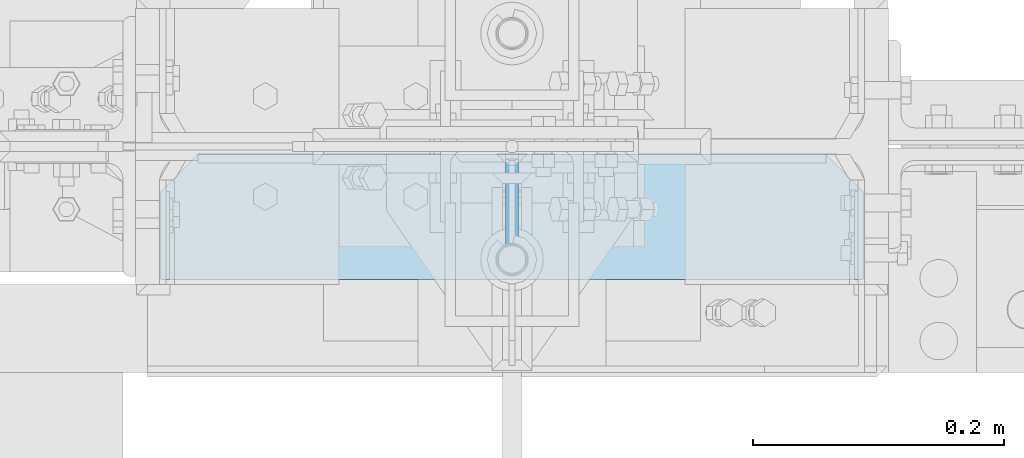
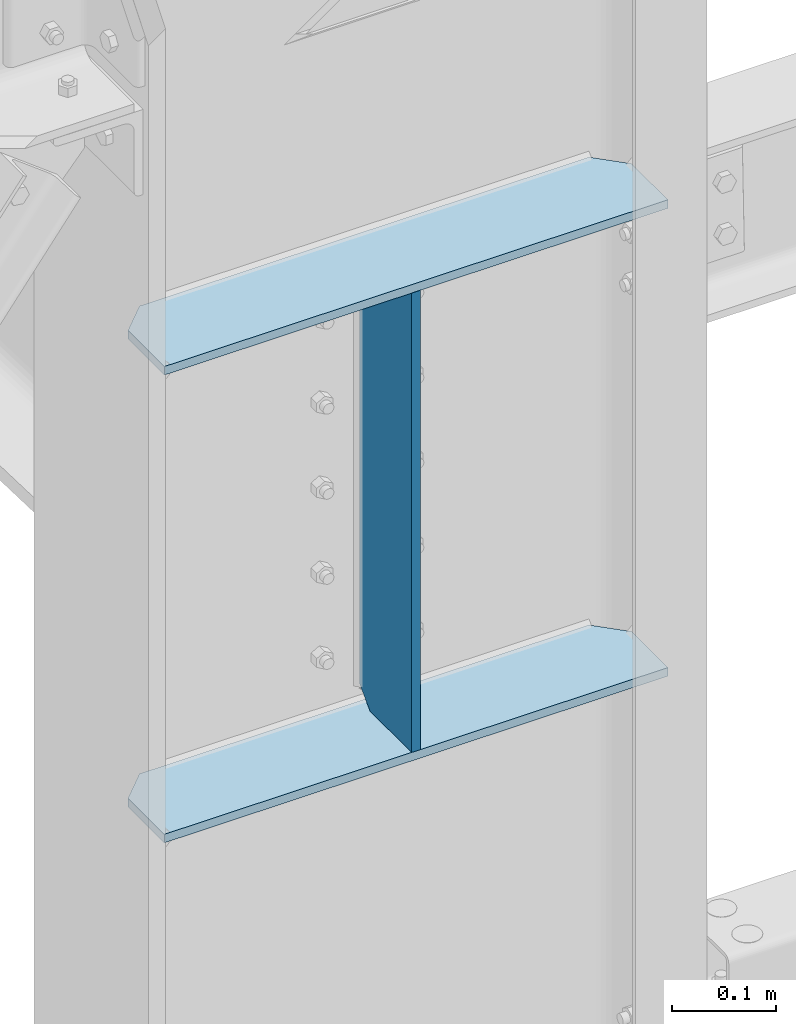
# One storey, part 130 of 496: 3 plates, 1 element without a shape of its own.
"""IFC2X3 building model written with IfcOpenShell, lengths in millimetres."""

from ifc_helpers import new_model, si_unit, frame, origin_with_axes, place, context, subcontext, project, spatial, polyline, outline, extrude, material, type_object, element, aggregate, save


model = new_model("IFC2X3")

# Units and contexts
model_context = context("Model", 3, precision=1e-05, world=origin_with_axes())
body_context = subcontext(model_context, "Body", "Model", "MODEL_VIEW")
ifc_project = project(units=[si_unit("LENGTHUNIT", "METRE", prefix="MILLI"), si_unit("AREAUNIT", "SQUARE_METRE"), si_unit("VOLUMEUNIT", "CUBIC_METRE"), si_unit("MASSUNIT", "GRAM", prefix="KILO"), si_unit("TIMEUNIT", "SECOND"), si_unit("PLANEANGLEUNIT", "RADIAN"), si_unit("SOLIDANGLEUNIT", "STERADIAN"), si_unit("THERMODYNAMICTEMPERATUREUNIT", "DEGREE_CELSIUS"), si_unit("LUMINOUSINTENSITYUNIT", "LUMEN")], contexts=[model_context])

# Site, building, storey
site_placement = place(None, origin_with_axes())
site = spatial("IfcSite", under=ifc_project, at=site_placement, CompositionType="ELEMENT")
building_placement = place(site_placement, origin_with_axes())
building = spatial("IfcBuilding", under=site, at=building_placement, Name="Undefined", CompositionType="ELEMENT")
storey_placement = place(building_placement, origin_with_axes())
storey = spatial("IfcBuildingStorey", under=building, at=storey_placement, Name="Undefined", CompositionType="ELEMENT", Elevation=0.0)

# Assembly, plates
assembly_placement = place(storey_placement, origin_with_axes())
assembly = element("IfcElementAssembly", 1, at=assembly_placement, inside=storey, Name="POTEAU", AssemblyPlace="NOTDEFINED", PredefinedType="NOTDEFINED")
ifc_material = material(Name="Undefined/S235-E24")
plate_type = type_object("IfcPlateType", PredefinedType="NOTDEFINED")
plate_1_placement = place(assembly_placement, frame((28879.9998414389, -106.0, 8044.34004841327), z_axis=(-1.0, 0.0, 0.0), x_axis=(0.0, 1.0, 0.0)))
plate_1 = element("IfcPlate", 2, at=plate_1_placement, type_object=plate_type, material=ifc_material, context=body_context, shape_type="SweptSolid", body=[
    extrude(outline(polyline([(0.0, 0.0), (80.00000000008, 8.00355337560177e-11), (100.0, 20.0), (100.0, 520.000000000172), (80.0, 540.000000000172), (-5.6843418860808e-14, 540.000000000172), (0.0, 0.0)])), frame((0.0, 0.0, -5.0), z_axis=(0.0, 0.0, 1.0), x_axis=(1.0, 0.0, 0.0)), (0.0, 0.0, 1.0), 10.0),
])
plate_2_placement = place(assembly_placement, frame((29159.9996632239, -106.0, 7499.33995685333), z_axis=(0.0, 0.0, 1.0), x_axis=(0.0, 1.0, 0.0)))
plate_2 = element("IfcPlate", 3, at=plate_2_placement, type_object=plate_type, material=ifc_material, context=body_context, shape_type="SweptSolid", body=[
    extrude(outline(polyline([(0.0, 0.0), (70.0, 0.0), (100.0, 30.0), (100.0, 530.000000000175), (70.0, 560.000000000175), (0.0, 560.000000000175), (0.0, 0.0)])), frame((0.0, 0.0, -5.0), z_axis=(0.0, 0.0, 1.0), x_axis=(1.0, 0.0, 0.0)), (0.0, 0.0, 1.0), 10.0),
])
plate_3_placement = place(assembly_placement, frame((29159.9998430739, -106.0, 8049.33995685327), z_axis=(0.0, 0.0, 1.0), x_axis=(0.0, 1.0, 0.0)))
plate_3 = element("IfcPlate", 4, at=plate_3_placement, type_object=plate_type, material=ifc_material, context=body_context, shape_type="SweptSolid", body=[
    extrude(outline(polyline([(0.0, 0.0), (70.0, 0.0), (100.0, 30.0), (100.0, 530.000000000175), (70.0, 560.000000000175), (0.0, 560.000000000175), (0.0, 0.0)])), frame((0.0, 0.0, -5.0), z_axis=(0.0, 0.0, 1.0), x_axis=(1.0, 0.0, 0.0)), (0.0, 0.0, 1.0), 10.0),
])
aggregate(assembly, [plate_1, plate_2, plate_3])

save(model, "model.ifc")
